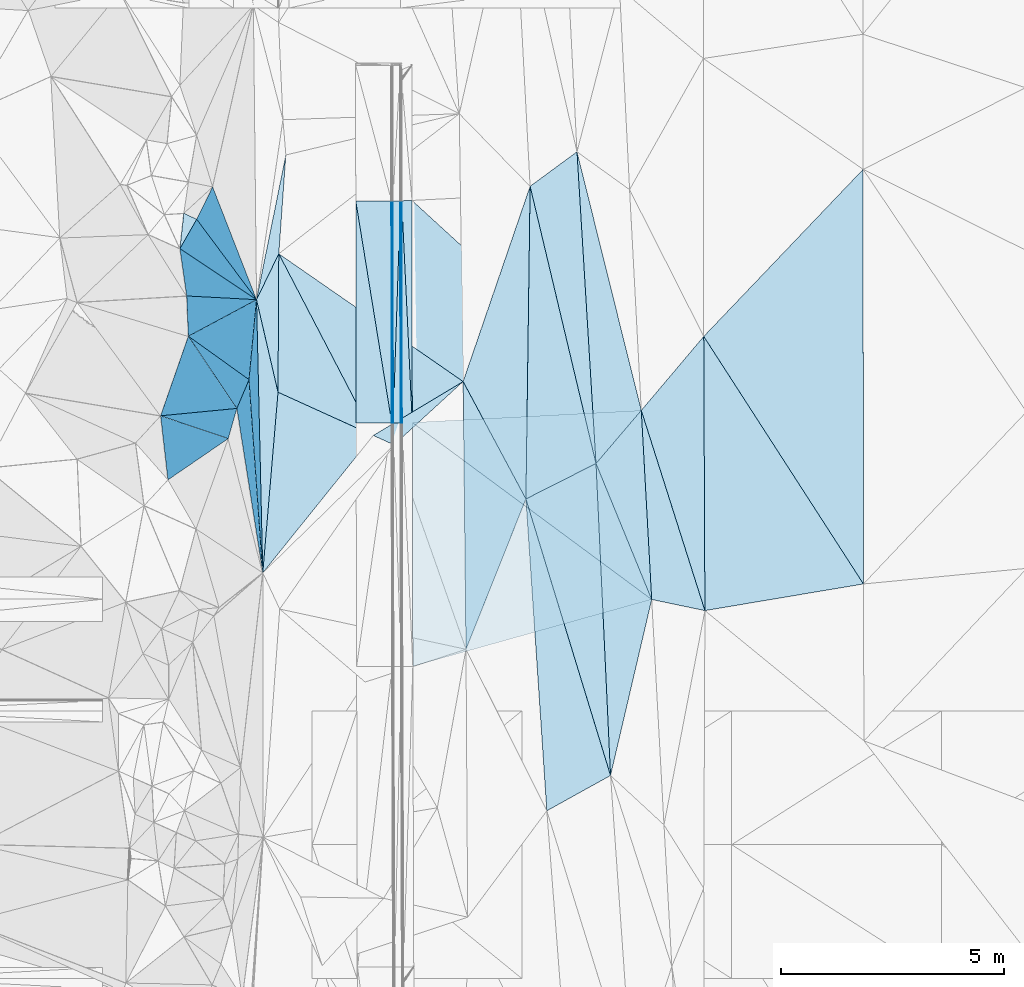
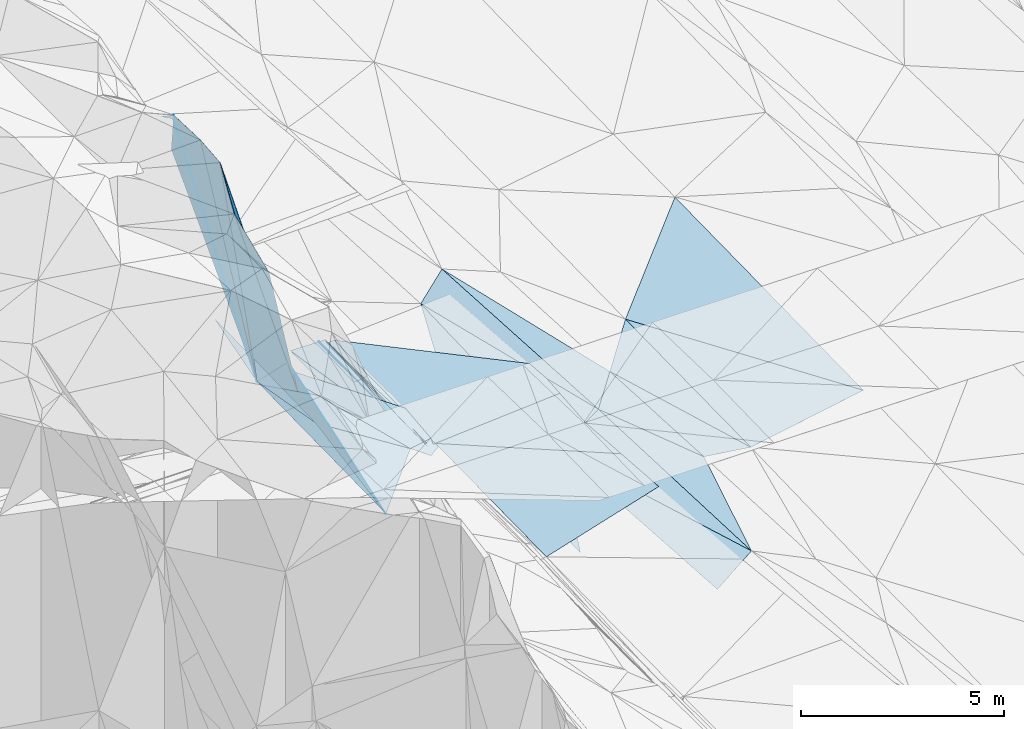
# One storey, part 82 of 275: 45 plates.
"""IFC2X3 building model written with IfcOpenShell, lengths in millimetres."""

import ifcopenshell
import ifcopenshell.guid

model = None  # the IFC model being written
_history = None  # IfcOwnerHistory: only IFC2X3 demands one
_inside = {}  # id of a spatial element -> (the spatial element, [elements in it])
_under = {}  # id of a project, library or spatial element -> (it, [spatial elements below it])
_declared = {}  # id of a project -> (the project, [libraries it declares])
_typed = {}  # id of a type object -> (the type object, [elements of that type])
_made_of = {}  # id of a material, layer set ... -> (it, [elements and type objects made of it])


def new_model(schema):
    """Start an empty IFC model of exactly this schema.

    Asked for "IFC4X3", IfcOpenShell would pick the latest addendum, in which some entities
    have other attributes; the version numbers below select the first issue.
    IFC2X3 requires an IfcOwnerHistory on every rooted entity: one is made here for all.
    """
    global model, _history
    if schema == "IFC4X3":
        model = ifcopenshell.file(schema_version=(4, 3, 0, 0))
    else:
        model = ifcopenshell.file(schema=schema)
    _inside.clear()
    _under.clear()
    _declared.clear()
    _typed.clear()
    _made_of.clear()
    _history = None
    if model.schema == "IFC2X3":
        org = make("IfcOrganization", Name="unknown")
        user = make(
            "IfcPersonAndOrganization",
            ThePerson=make("IfcPerson", FamilyName="unknown"),
            TheOrganization=org,
        )
        app = make(
            "IfcApplication",
            ApplicationDeveloper=org,
            Version="unknown",
            ApplicationFullName="unknown",
            ApplicationIdentifier="unknown",
        )
        _history = make(
            "IfcOwnerHistory",
            OwningUser=user,
            OwningApplication=app,
            ChangeAction="ADDED",
            CreationDate=0,
        )
    return model


def make(cls, **values):
    """One entity of the class cls with the attributes given. An attribute that is None is left unset."""
    return model.create_entity(
        cls, **{name: value for name, value in values.items() if value is not None}
    )


def rooted(cls, **values):
    """An entity with a GlobalId (a new one), such as an element, a storey or a relation."""
    return make(cls, GlobalId=ifcopenshell.guid.new(), OwnerHistory=_history, **values)


def si_unit(unit_type, name, prefix=None):
    """IfcSIUnit, for example si_unit("LENGTHUNIT", "METRE", prefix="MILLI")."""
    return make("IfcSIUnit", UnitType=unit_type, Prefix=prefix, Name=name)


def assignment(units):
    """IfcUnitAssignment: the units of a project."""
    return None if units is None else make("IfcUnitAssignment", Units=units)


def point(xyz):
    """IfcCartesianPoint."""
    return None if xyz is None else make("IfcCartesianPoint", Coordinates=xyz)


def direction(xyz):
    """IfcDirection."""
    return None if xyz is None else make("IfcDirection", DirectionRatios=xyz)


def frame(location, z_axis=None, x_axis=None):
    """IfcAxis2Placement3D, a coordinate frame: its origin and axes. An axis left out is left unset."""
    return make(
        "IfcAxis2Placement3D",
        Location=point(location),
        Axis=direction(z_axis),
        RefDirection=direction(x_axis),
    )


def origin_with_axes():
    """The frame at (0, 0, 0) with the z axis (0, 0, 1) and the x axis (1, 0, 0) written out."""
    return frame((0.0, 0.0, 0.0), z_axis=(0.0, 0.0, 1.0), x_axis=(1.0, 0.0, 0.0))


def place(relative_to, where):
    """IfcLocalPlacement: puts the frame where relative to a parent placement (None: the world)."""
    return make(
        "IfcLocalPlacement", PlacementRelTo=relative_to, RelativePlacement=where
    )


def context(
    kind, dimensions, precision=None, world=None, true_north=None, identifier=None
):
    """IfcGeometricRepresentationContext, for example the 3D "Model" context."""
    return make(
        "IfcGeometricRepresentationContext",
        ContextIdentifier=identifier,
        ContextType=kind,
        CoordinateSpaceDimension=dimensions,
        Precision=precision,
        WorldCoordinateSystem=world,
        TrueNorth=true_north,
    )


def subcontext(parent, identifier, kind, view, scale=None):
    """IfcGeometricRepresentationSubContext, for example "Body" below "Model"."""
    return make(
        "IfcGeometricRepresentationSubContext",
        ContextIdentifier=identifier,
        ContextType=kind,
        ParentContext=parent,
        TargetScale=scale,
        TargetView=view,
    )


def project(units=None, contexts=None):
    """IfcProject with its units and contexts."""
    return rooted(
        "IfcProject",
        Name="project",
        RepresentationContexts=contexts,
        UnitsInContext=assignment(units),
    )


def spatial(cls, under=None, at=None, **own):
    """A site, building, storey or space (cls), placed at a placement, below another one or the project."""
    s = rooted(cls, ObjectPlacement=at, **own)
    if under is not None:
        _under.setdefault(under.id(), (under, []))[1].append(s)
    return s


def polyline(points):
    """IfcPolyline through the points."""
    return make("IfcPolyline", Points=[point(p) for p in points])


def outline(outer, holes=None, kind="AREA"):
    """IfcArbitraryClosedProfileDef: a profile drawn as a closed curve; with holes, ...WithVoids."""
    if holes is None:
        return make("IfcArbitraryClosedProfileDef", ProfileType=kind, OuterCurve=outer)
    return make(
        "IfcArbitraryProfileDefWithVoids",
        ProfileType=kind,
        OuterCurve=outer,
        InnerCurves=holes,
    )


def extrude(swept, where, along, depth):
    """IfcExtrudedAreaSolid: the profile swept, set in the frame where, extruded along a direction by depth."""
    return make(
        "IfcExtrudedAreaSolid",
        SweptArea=swept,
        Position=where,
        ExtrudedDirection=direction(along),
        Depth=depth,
    )


def shape(context_of_items, identifier, shape_type, items):
    """IfcShapeRepresentation: the items that make up one representation, for example the "Body"."""
    return make(
        "IfcShapeRepresentation",
        ContextOfItems=context_of_items,
        RepresentationIdentifier=identifier,
        RepresentationType=shape_type,
        Items=items,
    )


def material(Name=None, Category=None):
    """IfcMaterial."""
    return make("IfcMaterial", Name=Name, Category=Category)


def made_of(thing, what):
    """Note that an element or type object is made of a material, layer set ...; save() writes the relation."""
    if what is not None:
        _made_of.setdefault(what.id(), (what, []))[1].append(thing)
    return thing


def type_object(cls, material=None, **own):
    """A type object (cls), such as IfcWallType, which elements share."""
    return made_of(rooted(cls, **own), material)


def element(
    cls,
    number,
    at=None,
    inside=None,
    cuts=None,
    type_object=None,
    material=None,
    context=None,
    identifier="Body",
    shape_type=None,
    held_by="IfcProductDefinitionShape",
    body=None,
    shapes=None,
    **own,
):
    """One element of the class cls, such as IfcWall. Its Tag is "e" and its number.

    at: its placement. inside: the storey or other place that contains it. cuts: it is an
    opening in that element (IfcRelVoidsElement). A single representation is given by context,
    identifier, shape_type and body (its items); several are given by shapes. held_by: the class
    of the entity that holds the representations. save() writes the other relations.
    """
    e = rooted(cls, Tag="e%d" % number, ObjectPlacement=at, **own)
    if body is not None:
        shapes = [shape(context, identifier, shape_type, body)]
    if shapes is not None:
        e.Representation = make(held_by, Representations=shapes)
    if inside is not None:
        _inside.setdefault(inside.id(), (inside, []))[1].append(e)
    if cuts is not None:
        rooted(
            "IfcRelVoidsElement", RelatingBuildingElement=cuts, RelatedOpeningElement=e
        )
    if type_object is not None:
        _typed.setdefault(type_object.id(), (type_object, []))[1].append(e)
    return made_of(e, material)


def aggregate(whole, parts):
    """IfcRelAggregates: a whole, such as a stair, and the parts it consists of."""
    return rooted("IfcRelAggregates", RelatingObject=whole, RelatedObjects=parts)


def save(model, path):
    """Write the relations noted so far, then the file.

    IfcRelAggregates (storeys below a building ...), IfcRelContainedInSpatialStructure (elements
    in a storey), IfcRelDefinesByType, IfcRelAssociatesMaterial and IfcRelDeclares: one each for
    every whole, place, type object, material and project.
    """
    for whole, parts in _under.values():
        aggregate(whole, parts)
    for where, things in _inside.values():
        rooted(
            "IfcRelContainedInSpatialStructure",
            RelatedElements=things,
            RelatingStructure=where,
        )
    for kind, things in _typed.values():
        rooted("IfcRelDefinesByType", RelatedObjects=things, RelatingType=kind)
    for what, things in _made_of.values():
        rooted("IfcRelAssociatesMaterial", RelatedObjects=things, RelatingMaterial=what)
    for by, libraries in _declared.values():
        rooted("IfcRelDeclares", RelatingContext=by, RelatedDefinitions=libraries)
    model.write(path)


model = new_model("IFC2X3")

# Units and contexts
model_context = context("Model", 3, precision=1e-05, world=origin_with_axes())
body_context = subcontext(model_context, "Body", "Model", "MODEL_VIEW")
ifc_project = project(units=[si_unit("LENGTHUNIT", "METRE", prefix="MILLI"), si_unit("AREAUNIT", "SQUARE_METRE"), si_unit("VOLUMEUNIT", "CUBIC_METRE"), si_unit("MASSUNIT", "GRAM", prefix="KILO"), si_unit("TIMEUNIT", "SECOND"), si_unit("PLANEANGLEUNIT", "RADIAN"), si_unit("SOLIDANGLEUNIT", "STERADIAN"), si_unit("THERMODYNAMICTEMPERATUREUNIT", "DEGREE_CELSIUS"), si_unit("LUMINOUSINTENSITYUNIT", "LUMEN")], contexts=[model_context])

# Site, building, storey
site_placement = place(None, origin_with_axes())
site = spatial("IfcSite", under=ifc_project, at=site_placement, CompositionType="ELEMENT")
building_placement = place(site_placement, origin_with_axes())
building = spatial("IfcBuilding", under=site, at=building_placement, Name="Undefined", CompositionType="ELEMENT")
storey_placement = place(building_placement, origin_with_axes())
storey = spatial("IfcBuildingStorey", under=building, at=storey_placement, Name="Undefined", CompositionType="ELEMENT", Elevation=0.0)

# Plates
ifc_material = material()
plate_type_1 = type_object("IfcPlateType", PredefinedType="NOTDEFINED")
plate_1_placement = place(storey_placement, frame((-89444.618863337, 64842.7358949304, 42407.5032804779), z_axis=(0.111617782636541, 0.0258237685561745, -0.993415624789976), x_axis=(-0.869160661525397, -0.48209765936178, -0.11018888916142)))
element("IfcPlate", 1, at=plate_1_placement, inside=storey, type_object=plate_type_1, material=ifc_material, Name="00", context=body_context, shape_type="SweptSolid", body=[
    extrude(outline(polyline([(0.0, 0.0), (1642.63391113281, -5.03496266901493e-09), (-1333.244140625, 6341.60546875), (0.0, 0.0)])), frame((-8.85201319254618e-08, 2.18876761149539e-07, -0.5000001331573), z_axis=(0.0, 0.0, 1.0), x_axis=(1.0, 0.0, 0.0)), (0.0, 0.0, 1.0), 1.0),
])
plate_type_2 = type_object("IfcPlateType", PredefinedType="NOTDEFINED")
plate_2_placement = place(storey_placement, frame((-94117.6604189031, 72746.729349898, 42397.8747366378), z_axis=(-0.970138594073752, 0.00347870184175946, -0.242526301505836), x_axis=(-0.00731542211713824, 0.999022621098165, 0.043592282956971)))
element("IfcPlate", 2, at=plate_2_placement, inside=storey, type_object=plate_type_2, material=ifc_material, Name="00_PR", context=body_context, shape_type="SweptSolid", body=[
    extrude(outline(polyline([(0.0, 0.0), (4977.96826171875, -7.34871719032526e-09), (4972.70556640625, 123.581230163574), (0.0, 0.0)])), frame((-8.85201319254618e-08, 2.18876761149539e-07, -0.5000001331573), z_axis=(0.0, 0.0, 1.0), x_axis=(1.0, 0.0, 0.0)), (0.0, 0.0, 1.0), 1.0),
])
plate_3_placement = place(storey_placement, frame((-94117.6604189031, 72746.729349898, 42397.8747366378), z_axis=(-0.970141199124637, 0.00347822856618674, -0.242515887494103), x_axis=(-0.242522932028191, -0.00176481198317647, 0.970144068104894)))
element("IfcPlate", 3, at=plate_3_placement, inside=storey, type_object=plate_type_2, material=ifc_material, Name="00_PR", context=body_context, shape_type="SweptSolid", body=[
    extrude(outline(polyline([(0.0, 0.0), (123.69295501709, -7.27595761418343e-11), (210.577346801758, 4973.51220703125), (0.0, 0.0)])), frame((-8.85201319254618e-08, 2.18876761149539e-07, -0.5000001331573), z_axis=(0.0, 0.0, 1.0), x_axis=(1.0, 0.0, 0.0)), (0.0, 0.0, 1.0), 1.0),
])
plate_type_3 = type_object("IfcPlateType", PredefinedType="NOTDEFINED")
plate_4_placement = place(storey_placement, frame((-94317.1841480322, 72746.228678352, 42517.4961943579), z_axis=(-0.0200252966545819, 0.0194701752981887, -0.999609873784645), x_axis=(-0.999798643815819, -0.00167813309841074, 0.0199963920083956)))
element("IfcPlate", 4, at=plate_4_placement, inside=storey, type_object=plate_type_3, material=ifc_material, Name="00_PR", context=body_context, shape_type="SweptSolid", body=[
    extrude(outline(polyline([(0.0, 0.0), (30.0054130554199, -7.27595761418343e-11), (30.0149536132813, 4974.4365234375), (0.0, 0.0)])), frame((-8.85201319254618e-08, 2.18876761149539e-07, -0.5000001331573), z_axis=(0.0, 0.0, 1.0), x_axis=(1.0, 0.0, 0.0)), (0.0, 0.0, 1.0), 1.0),
])
plate_5_placement = place(storey_placement, frame((-94353.6008469605, 77719.6646390638, 42615.0971946187), z_axis=(-0.020009290866159, 0.0194702016103161, -0.999610193789703), x_axis=(0.999799667779248, 0.000886280119676432, -0.0199959699953689)))
element("IfcPlate", 5, at=plate_5_placement, inside=storey, type_object=plate_type_3, material=ifc_material, Name="00_PR", context=body_context, shape_type="SweptSolid", body=[
    extrude(outline(polyline([(0.0, 0.0), (30.006046295166, -5.82076609134674e-11), (33.9531784057617, 4974.4111328125), (0.0, 0.0)])), frame((-8.85201319254618e-08, 2.18876761149539e-07, -0.5000001331573), z_axis=(0.0, 0.0, 1.0), x_axis=(1.0, 0.0, 0.0)), (0.0, 0.0, 1.0), 1.0),
])
plate_type_4 = type_object("IfcPlateType", PredefinedType="NOTDEFINED")
plate_6_placement = place(storey_placement, frame((-95153.6003904892, 77718.9630360176, 42631.0971939899), z_axis=(-0.020009290866159, 0.0194702016103161, -0.999610193789703), x_axis=(0.999799675411591, 0.000876829116764039, -0.0199960050404666)))
element("IfcPlate", 6, at=plate_6_placement, inside=storey, type_object=plate_type_4, material=ifc_material, Name="00_PR", context=body_context, shape_type="SweptSolid", body=[
    extrude(outline(polyline([(0.0, 0.0), (800.159851074219, -2.4156179279089e-09), (804.154602050781, 4974.4345703125), (0.0, 0.0)])), frame((-8.85201319254618e-08, 2.18876761149539e-07, -0.5000001331573), z_axis=(0.0, 0.0, 1.0), x_axis=(1.0, 0.0, 0.0)), (0.0, 0.0, 1.0), 1.0),
])
plate_7_placement = place(storey_placement, frame((-94347.1835203325, 72746.1783233951, 42518.0961940679), z_axis=(-0.0200253858209845, 0.0194675856213308, -0.999609922436146), x_axis=(-0.999798609242098, -0.00170328511816342, 0.0199959940331207)))
element("IfcPlate", 7, at=plate_7_placement, inside=storey, type_object=plate_type_4, material=ifc_material, Name="00_PR", context=body_context, shape_type="SweptSolid", body=[
    extrude(outline(polyline([(0.0, 0.0), (800.160278320313, 5.5297277867794e-09), (800.0439453125, 4975.09765625), (0.0, 0.0)])), frame((-8.85201319254618e-08, 2.18876761149539e-07, -0.5000001331573), z_axis=(0.0, 0.0, 1.0), x_axis=(1.0, 0.0, 0.0)), (0.0, 0.0, 1.0), 1.0),
])
plate_type_5 = type_object("IfcPlateType", PredefinedType="NOTDEFINED")
plate_8_placement = place(storey_placement, frame((-94123.5755587747, 77720.0284364157, 42494.4973540296), z_axis=(0.0321667670477351, 0.01953207219902, -0.999291647745196), x_axis=(0.0475300560924656, -0.998707779540465, -0.0179906879579957)))
element("IfcPlate", 8, at=plate_8_placement, inside=storey, type_object=plate_type_5, material=ifc_material, Name="00_PR", context=body_context, shape_type="SweptSolid", body=[
    extrude(outline(polyline([(0.0, 0.0), (4973.85107421875, 3.33529897034168e-08), (4968.91455078125, 230.135818481445), (0.0, 0.0)])), frame((-8.85201319254618e-08, 2.18876761149539e-07, -0.5000001331573), z_axis=(0.0, 0.0, 1.0), x_axis=(1.0, 0.0, 0.0)), (0.0, 0.0, 1.0), 1.0),
])
plate_9_placement = place(storey_placement, frame((-93893.5824311411, 77728.6313530642, 42502.0183500543), z_axis=(0.0319478192432614, 0.0195217824957028, -0.999298872637106), x_axis=(0.00128876911653835, -0.999809210568277, -0.0194905499410143)))
element("IfcPlate", 9, at=plate_9_placement, inside=storey, type_object=plate_type_5, material=ifc_material, Name="00_PR", context=body_context, shape_type="SweptSolid", body=[
    extrude(outline(polyline([(0.0, 0.0), (4976.97607421875, 3.05008143186569e-08), (8.45146083831787, 230.121795654297), (0.0, 0.0)])), frame((-8.85201319254618e-08, 2.18876761149539e-07, -0.5000001331573), z_axis=(0.0, 0.0, 1.0), x_axis=(1.0, 0.0, 0.0)), (0.0, 0.0, 1.0), 1.0),
])
plate_type_6 = type_object("IfcPlateType", PredefinedType="NOTDEFINED")
plate_10_placement = place(storey_placement, frame((-94317.1741466871, 72746.2286934931, 42517.4960946812), z_axis=(-1.70839782126875e-05, 0.0194999851390157, -0.99980985706669), x_axis=(-0.00128993512309353, 0.999809024974403, 0.0194999909515573)))
element("IfcPlate", 10, at=plate_10_placement, inside=storey, type_object=plate_type_6, material=ifc_material, Name="00_PR", context=body_context, shape_type="SweptSolid", body=[
    extrude(outline(polyline([(0.0, 0.0), (4974.41259765625, -2.84344423562288e-08), (4974.34228515625, 169.999572753906), (0.0, 0.0)])), frame((-8.85201319254618e-08, 2.18876761149539e-07, -0.5000001331573), z_axis=(0.0, 0.0, 1.0), x_axis=(1.0, 0.0, 0.0)), (0.0, 0.0, 1.0), 1.0),
])
plate_11_placement = place(storey_placement, frame((-94153.591302071, 77719.8401820508, 42614.4970950768), z_axis=(-3.33079408345215e-05, 0.0195005182108535, -0.999809846260822), x_axis=(0.00129015010064996, -0.999809013891711, -0.0195005449565535)))
element("IfcPlate", 11, at=plate_11_placement, inside=storey, type_object=plate_type_6, material=ifc_material, Name="00_PR", context=body_context, shape_type="SweptSolid", body=[
    extrude(outline(polyline([(0.0, 0.0), (4974.27099609375, -3.19123500958085e-08), (4974.34228515625, 170.000640869141), (0.0, 0.0)])), frame((-8.85201319254618e-08, 2.18876761149539e-07, -0.5000001331573), z_axis=(0.0, 0.0, 1.0), x_axis=(1.0, 0.0, 0.0)), (0.0, 0.0, 1.0), 1.0),
])
plate_type_7 = type_object("IfcPlateType", PredefinedType="NOTDEFINED")
plate_12_placement = place(storey_placement, frame((-88755.828340706, 73023.8678780256, 42559.3353079388), z_axis=(0.029013693312706, 0.019711028854778, -0.999384651143814), x_axis=(0.0549715490951405, -0.998323959821758, -0.0180941989567237)))
element("IfcPlate", 12, at=plate_12_placement, inside=storey, type_object=plate_type_7, material=ifc_material, Name="00_PR", context=body_context, shape_type="SweptSolid", body=[
    extrude(outline(polyline([(0.0, 0.0), (4244.6201171875, 2.48837750405073e-09), (-8.47717952728271, 5140.81640625), (0.0, 0.0)])), frame((-8.85201319254618e-08, 2.18876761149539e-07, -0.5000001331573), z_axis=(0.0, 0.0, 1.0), x_axis=(1.0, 0.0, 0.0)), (0.0, 0.0, 1.0), 1.0),
])
plate_type_8 = type_object("IfcPlateType", PredefinedType="NOTDEFINED")
plate_13_placement = place(storey_placement, frame((-93887.169717697, 72752.6048438911, 42405.0143065105), z_axis=(0.0290239089952379, 0.0195197531379186, -0.999388108766595), x_axis=(-0.00128876910606511, 0.999809210568024, 0.0194905499547063)))
element("IfcPlate", 13, at=plate_13_placement, inside=storey, type_object=plate_type_8, material=ifc_material, Name="00_PR", context=body_context, shape_type="SweptSolid", body=[
    extrude(outline(polyline([(0.0, 0.0), (4976.97607421875, 3.05008143186569e-08), (267.605865478516, 5133.853515625), (0.0, 0.0)])), frame((-8.85201319254618e-08, 2.18876761149539e-07, -0.5000001331573), z_axis=(0.0, 0.0, 1.0), x_axis=(1.0, 0.0, 0.0)), (0.0, 0.0, 1.0), 1.0),
])
plate_type_9 = type_object("IfcPlateType", PredefinedType="NOTDEFINED")
plate_14_placement = place(storey_placement, frame((-93875.3877965251, 67289.1652421238, 42297.782307639), z_axis=(0.0289890427295221, 0.0196776603535674, -0.99938602405909), x_axis=(-0.00215608511128748, 0.999805118314905, 0.0196233709721959)))
element("IfcPlate", 14, at=plate_14_placement, inside=storey, type_object=plate_type_9, material=ifc_material, Name="00_PR", context=body_context, shape_type="SweptSolid", body=[
    extrude(outline(polyline([(0.0, 0.0), (5464.50439453125, 1.28202373161912e-08), (1488.98913574219, 5358.36767578125), (0.0, 0.0)])), frame((-8.85201319254618e-08, 2.18876761149539e-07, -0.5000001331573), z_axis=(0.0, 0.0, 1.0), x_axis=(1.0, 0.0, 0.0)), (0.0, 0.0, 1.0), 1.0),
])
plate_type_10 = type_object("IfcPlateType", PredefinedType="NOTDEFINED")
plate_15_placement = place(storey_placement, frame((-99526.9349128616, 72902.6245616917, 51199.8605269256), z_axis=(-0.893965103901235, 0.350744833349942, -0.278934499273888), x_axis=(0.326341170728292, 0.936102852952924, 0.131197900063545)))
element("IfcPlate", 15, at=plate_15_placement, inside=storey, type_object=plate_type_10, material=ifc_material, Name="00", context=body_context, shape_type="SweptSolid", body=[
    extrude(outline(polyline([(0.0, 0.0), (1905.51831054688, 6.57746568322182e-09), (20.9916648864746, 5542.64892578125), (0.0, 0.0)])), frame((-8.85201319254618e-08, 2.18876761149539e-07, -0.5000001331573), z_axis=(0.0, 0.0, 1.0), x_axis=(1.0, 0.0, 0.0)), (0.0, 0.0, 1.0), 1.0),
])
plate_type_11 = type_object("IfcPlateType", PredefinedType="NOTDEFINED")
plate_16_placement = place(storey_placement, frame((-88522.4927132035, 68786.362588593, 42529.5003792916), z_axis=(0.0338025597203587, 0.0207254823291996, -0.999213611465824), x_axis=(-0.378908875488096, 0.925412018442613, 0.00637653497719486)))
element("IfcPlate", 16, at=plate_16_placement, inside=storey, type_object=plate_type_11, material=ifc_material, Name="00", context=body_context, shape_type="SweptSolid", body=[
    extrude(outline(polyline([(0.0, 0.0), (3293.32446289063, 7.50151230022311e-09), (4010.36108398438, 1390.79284667969), (0.0, 0.0)])), frame((-8.85201319254618e-08, 2.18876761149539e-07, -0.5000001331573), z_axis=(0.0, 0.0, 1.0), x_axis=(1.0, 0.0, 0.0)), (0.0, 0.0, 1.0), 1.0),
])
plate_type_12 = type_object("IfcPlateType", PredefinedType="NOTDEFINED")
plate_17_placement = place(storey_placement, frame((-91246.9022901931, 78045.3959095917, 42477.5079083627), z_axis=(0.174731865229497, 0.0299721132208858, -0.984159767366303), x_axis=(0.795259158073839, 0.585045632730831, 0.159010940259691)))
element("IfcPlate", 17, at=plate_17_placement, inside=storey, type_object=plate_type_12, material=ifc_material, Name="00", context=body_context, shape_type="SweptSolid", body=[
    extrude(outline(polyline([(0.0, 0.0), (1320.66381835938, 1.06228981167078e-09), (-2448.02563476563, 5896.92333984375), (0.0, 0.0)])), frame((-8.85201319254618e-08, 2.18876761149539e-07, -0.5000001331573), z_axis=(0.0, 0.0, 1.0), x_axis=(1.0, 0.0, 0.0)), (0.0, 0.0, 1.0), 1.0),
])
plate_type_13 = type_object("IfcPlateType", PredefinedType="NOTDEFINED")
plate_18_placement = place(storey_placement, frame((-97545.4361877179, 73712.9885815757, 45539.8724302355), z_axis=(-0.936376961903715, 0.241057644960747, -0.255126237423647), x_axis=(-0.339766455862014, -0.804900041873057, 0.486512772765234)))
element("IfcPlate", 18, at=plate_18_placement, inside=storey, type_object=plate_type_13, material=ifc_material, Name="00", context=body_context, shape_type="SweptSolid", body=[
    extrude(outline(polyline([(0.0, 0.0), (801.623352050781, 5.23868948221207e-10), (2553.81787109375, 5585.89404296875), (0.0, 0.0)])), frame((-8.85201319254618e-08, 2.18876761149539e-07, -0.5000001331573), z_axis=(0.0, 0.0, 1.0), x_axis=(1.0, 0.0, 0.0)), (0.0, 0.0, 1.0), 1.0),
])
plate_type_14 = type_object("IfcPlateType", PredefinedType="NOTDEFINED")
plate_19_placement = place(storey_placement, frame((-97237.6372222059, 69383.6968796635, 43503.7932261013), z_axis=(-0.901099746077251, 0.130418655315721, -0.413533822032919), x_axis=(-0.130397977254679, 0.828045649039805, 0.545285953087127)))
element("IfcPlate", 19, at=plate_19_placement, inside=storey, type_object=plate_type_14, material=ifc_material, Name="00", context=body_context, shape_type="SweptSolid", body=[
    extrude(outline(polyline([(0.0, 0.0), (4449.0419921875, -8.53469828143716e-09), (4735.1416015625, 748.830383300781), (0.0, 0.0)])), frame((-8.85201319254618e-08, 2.18876761149539e-07, -0.5000001331573), z_axis=(0.0, 0.0, 1.0), x_axis=(1.0, 0.0, 0.0)), (0.0, 0.0, 1.0), 1.0),
])
plate_type_15 = type_object("IfcPlateType", PredefinedType="NOTDEFINED")
plate_20_placement = place(storey_placement, frame((-97817.7752682129, 73067.8290097536, 45929.8623472046), z_axis=(-0.885098503409818, 0.375254186611925, -0.275290636767623), x_axis=(-0.252828330677899, -0.884304602678622, -0.392534335935127)))
element("IfcPlate", 20, at=plate_20_placement, inside=storey, type_object=plate_type_15, material=ifc_material, Name="00", context=body_context, shape_type="SweptSolid", body=[
    extrude(outline(polyline([(0.0, 0.0), (764.264343261719, 2.09547579288483e-09), (-1490.45288085938, 5338.53466796875), (0.0, 0.0)])), frame((-8.85201319254618e-08, 2.18876761149539e-07, -0.5000001331573), z_axis=(0.0, 0.0, 1.0), x_axis=(1.0, 0.0, 0.0)), (0.0, 0.0, 1.0), 1.0),
])
plate_type_16 = type_object("IfcPlateType", PredefinedType="NOTDEFINED")
plate_21_placement = place(storey_placement, frame((-98011.0408968191, 72391.8333191524, 45629.8660662042), z_axis=(-0.960996882613753, 0.068837372997665, -0.267855199100985), x_axis=(-0.27619437110143, -0.18915092210665, 0.942304938986361)))
element("IfcPlate", 21, at=plate_21_placement, inside=storey, type_object=plate_type_16, material=ifc_material, Name="00", context=body_context, shape_type="SweptSolid", body=[
    extrude(outline(polyline([(0.0, 0.0), (4892.25927734375, -1.82189978659153e-08), (5570.7392578125, 1597.048828125), (0.0, 0.0)])), frame((-8.85201319254618e-08, 2.18876761149539e-07, -0.5000001331573), z_axis=(0.0, 0.0, 1.0), x_axis=(1.0, 0.0, 0.0)), (0.0, 0.0, 1.0), 1.0),
])
plate_type_17 = type_object("IfcPlateType", PredefinedType="NOTDEFINED")
plate_22_placement = place(storey_placement, frame((-96895.8161003144, 73431.36735261, 43659.5142441809), z_axis=(-0.236255539126644, 0.0201061786781543, -0.971482918949654), x_axis=(-0.225560327579383, 0.971341302561202, 0.0749574049776886)))
element("IfcPlate", 22, at=plate_22_placement, inside=storey, type_object=plate_type_17, material=ifc_material, Name="00", context=body_context, shape_type="SweptSolid", body=[
    extrude(outline(polyline([(0.0, 0.0), (2134.54565429688, -1.22672645375133e-08), (3013.56396484375, 737.449340820313), (0.0, 0.0)])), frame((-8.85201319254618e-08, 2.18876761149539e-07, -0.5000001331573), z_axis=(0.0, 0.0, 1.0), x_axis=(1.0, 0.0, 0.0)), (0.0, 0.0, 1.0), 1.0),
])
plate_type_18 = type_object("IfcPlateType", PredefinedType="NOTDEFINED")
plate_23_placement = place(storey_placement, frame((-98905.1252013776, 74686.1569161123, 51449.8968953098), z_axis=(-0.972665374619554, -0.106825266438722, -0.206180579751098), x_axis=(0.195220977160067, 0.104612139896346, -0.97516412478258)))
element("IfcPlate", 23, at=plate_23_placement, inside=storey, type_object=plate_type_18, material=ifc_material, Name="00", context=body_context, shape_type="SweptSolid", body=[
    extrude(outline(polyline([(0.0, 0.0), (7824.32373046875, 1.78260961547494e-08), (5926.8330078125, 1611.47521972656), (0.0, 0.0)])), frame((-8.85201319254618e-08, 2.18876761149539e-07, -0.5000001331573), z_axis=(0.0, 0.0, 1.0), x_axis=(1.0, 0.0, 0.0)), (0.0, 0.0, 1.0), 1.0),
])
plate_type_19 = type_object("IfcPlateType", PredefinedType="NOTDEFINED")
plate_24_placement = place(storey_placement, frame((-97237.2472762929, 69383.6559207232, 43503.5042452178), z_axis=(-0.120978364273596, 0.0484179656022729, -0.991473618400723), x_axis=(-0.0228320855741197, 0.998409762151338, 0.0515426300186985)))
element("IfcPlate", 24, at=plate_24_placement, inside=storey, type_object=plate_type_19, material=ifc_material, Name="00", context=body_context, shape_type="SweptSolid", body=[
    extrude(outline(polyline([(0.0, 0.0), (6130.84765625, -2.41125235334039e-08), (4041.53247070313, 437.090545654297), (0.0, 0.0)])), frame((-8.85201319254618e-08, 2.18876761149539e-07, -0.5000001331573), z_axis=(0.0, 0.0, 1.0), x_axis=(1.0, 0.0, 0.0)), (0.0, 0.0, 1.0), 1.0),
])
plate_type_20 = type_object("IfcPlateType", PredefinedType="NOTDEFINED")
plate_25_placement = place(storey_placement, frame((-92683.5117807389, 67670.551737333, 41770.5253671448), z_axis=(0.311928555269229, 0.0405245911667071, -0.949240925117761), x_axis=(-0.0107042575474713, 0.999176443251114, 0.0391389080380563)))
element("IfcPlate", 25, at=plate_25_placement, inside=storey, type_object=plate_type_20, material=ifc_material, Name="00", context=body_context, shape_type="SweptSolid", body=[
    extrude(outline(polyline([(0.0, 0.0), (6004.25537109375, 5.23868948221207e-09), (3374.2734375, 1451.22302246094), (0.0, 0.0)])), frame((-8.85201319254618e-08, 2.18876761149539e-07, -0.5000001331573), z_axis=(0.0, 0.0, 1.0), x_axis=(1.0, 0.0, 0.0)), (0.0, 0.0, 1.0), 1.0),
])
plate_type_21 = type_object("IfcPlateType", PredefinedType="NOTDEFINED")
plate_26_placement = place(storey_placement, frame((-96719.7695113017, 78746.3148947997, 43519.5020192317), z_axis=(-0.0165373947187794, -0.0888138181243595, -0.995910949978003), x_axis=(-0.0712255523608248, -0.993412101902716, 0.0897736959477695)))
element("IfcPlate", 26, at=plate_26_placement, inside=storey, type_object=plate_type_21, material=ifc_material, Name="00", context=body_context, shape_type="SweptSolid", body=[
    extrude(outline(polyline([(0.0, 0.0), (2227.82397460938, 1.12049747258425e-09), (3294.0302734375, 423.921173095703), (0.0, 0.0)])), frame((-8.85201319254618e-08, 2.18876761149539e-07, -0.5000001331573), z_axis=(0.0, 0.0, 1.0), x_axis=(1.0, 0.0, 0.0)), (0.0, 0.0, 1.0), 1.0),
])
plate_type_22 = type_object("IfcPlateType", PredefinedType="NOTDEFINED")
plate_27_placement = place(storey_placement, frame((-99007.0875013528, 77439.7954360325, 51199.6252177601), z_axis=(-0.456508555733989, -0.479406470526146, -0.74951275810311), x_axis=(0.872492883644568, -0.406184288577308, -0.271607237942091)))
element("IfcPlate", 27, at=plate_27_placement, inside=storey, type_object=plate_type_22, material=ifc_material, Name="00", context=body_context, shape_type="SweptSolid", body=[
    extrude(outline(polyline([(0.0, 0.0), (331.36083984375, -1.82262738235295e-09), (94.1571731567383, 969.966186523438), (0.0, 0.0)])), frame((-8.85201319254618e-08, 2.18876761149539e-07, -0.5000001331573), z_axis=(0.0, 0.0, 1.0), x_axis=(1.0, 0.0, 0.0)), (0.0, 0.0, 1.0), 1.0),
])
plate_type_23 = type_object("IfcPlateType", PredefinedType="NOTDEFINED")
plate_28_placement = place(storey_placement, frame((-98718.2122566056, 77305.5865701523, 51109.8790209249), z_axis=(-0.925952106124408, 0.289989132058421, -0.241907007859999), x_axis=(0.175748817291903, -0.236071258755388, -0.955710580672906)))
element("IfcPlate", 28, at=plate_28_placement, inside=storey, type_object=plate_type_23, material=ifc_material, Name="00", context=body_context, shape_type="SweptSolid", body=[
    extrude(outline(polyline([(0.0, 0.0), (7627.83203125, 2.07292032428086e-08), (-531.898193359375, 845.094299316406), (0.0, 0.0)])), frame((-8.85201319254618e-08, 2.18876761149539e-07, -0.5000001331573), z_axis=(0.0, 0.0, 1.0), x_axis=(1.0, 0.0, 0.0)), (0.0, 0.0, 1.0), 1.0),
])
plate_type_24 = type_object("IfcPlateType", PredefinedType="NOTDEFINED")
plate_29_placement = place(storey_placement, frame((-97377.6634238785, 75504.7212151671, 43819.9427660834), z_axis=(-0.993290837836147, -0.0168083813639197, -0.114414989344445), x_axis=(0.0228320856720504, -0.998409762147871, -0.0515426300424877)))
element("IfcPlate", 29, at=plate_29_placement, inside=storey, type_object=plate_type_24, material=ifc_material, Name="00", context=body_context, shape_type="SweptSolid", body=[
    extrude(outline(polyline([(0.0, 0.0), (6130.84765625, -2.41125235334039e-08), (1696.52746582031, 1821.84509277344), (0.0, 0.0)])), frame((-8.85201319254618e-08, 2.18876761149539e-07, -0.5000001331573), z_axis=(0.0, 0.0, 1.0), x_axis=(1.0, 0.0, 0.0)), (0.0, 0.0, 1.0), 1.0),
])
plate_type_25 = type_object("IfcPlateType", PredefinedType="NOTDEFINED")
plate_30_placement = place(storey_placement, frame((-89444.6560042261, 64842.7340774435, 42407.5004557413), z_axis=(0.0373439168340728, 0.022174403682829, -0.999056418675543), x_axis=(-0.0465268995538914, 0.998708147253829, 0.0204275359925161)))
element("IfcPlate", 30, at=plate_30_placement, inside=storey, type_object=plate_type_25, material=ifc_material, Name="00", context=body_context, shape_type="SweptSolid", body=[
    extrude(outline(polyline([(0.0, 0.0), (7000.3544921875, -2.15222826227546e-08), (3898.12133789063, 1105.50170898438), (0.0, 0.0)])), frame((-8.85201319254618e-08, 2.18876761149539e-07, -0.5000001331573), z_axis=(0.0, 0.0, 1.0), x_axis=(1.0, 0.0, 0.0)), (0.0, 0.0, 1.0), 1.0),
])
plate_type_26 = type_object("IfcPlateType", PredefinedType="NOTDEFINED")
plate_31_placement = place(storey_placement, frame((-88755.8265651422, 73023.8688442054, 42609.5003715389), z_axis=(0.0327755641257359, 0.0216019544793076, -0.999229261960894), x_axis=(-0.648369271380963, -0.760391721310291, -0.0377056771811845)))
element("IfcPlate", 31, at=plate_31_placement, inside=storey, type_object=plate_type_26, material=ifc_material, Name="00", context=body_context, shape_type="SweptSolid", body=[
    extrude(outline(polyline([(0.0, 0.0), (1564.75109863281, 1.57160684466362e-09), (-3474.56079101563, 4856.13623046875), (0.0, 0.0)])), frame((-8.85201319254618e-08, 2.18876761149539e-07, -0.5000001331573), z_axis=(0.0, 0.0, 1.0), x_axis=(1.0, 0.0, 0.0)), (0.0, 0.0, 1.0), 1.0),
])
plate_type_27 = type_object("IfcPlateType", PredefinedType="NOTDEFINED")
plate_32_placement = place(storey_placement, frame((-87356.4704042934, 74681.2163072877, 42689.5003430475), z_axis=(0.0300064121012802, 0.0229000282768895, -0.999287348032449), x_axis=(0.00431543567324925, -0.999731174139613, -0.022780616066739)))
element("IfcPlate", 32, at=plate_32_placement, inside=storey, type_object=plate_type_27, material=ifc_material, Name="00", context=body_context, shape_type="SweptSolid", body=[
    extrude(outline(polyline([(0.0, 0.0), (6145.57568359375, -3.14903445541859e-08), (1652.68493652344, 1407.13635253906), (0.0, 0.0)])), frame((-8.85201319254618e-08, 2.18876761149539e-07, -0.5000001331573), z_axis=(0.0, 0.0, 1.0), x_axis=(1.0, 0.0, 0.0)), (0.0, 0.0, 1.0), 1.0),
])
plate_type_28 = type_object("IfcPlateType", PredefinedType="NOTDEFINED")
plate_33_placement = place(storey_placement, frame((-97377.6553751076, 75504.7674886127, 43819.9007703412), z_axis=(-0.977188059161115, 0.0757464372652622, -0.198408604335982), x_axis=(-0.175748817291369, 0.236071258756997, 0.955710580672607)))
element("IfcPlate", 33, at=plate_33_placement, inside=storey, type_object=plate_type_28, material=ifc_material, Name="00", context=body_context, shape_type="SweptSolid", body=[
    extrude(outline(polyline([(0.0, 0.0), (7627.83203125, 2.07292032428086e-08), (6322.1298828125, 1067.86743164063), (0.0, 0.0)])), frame((-8.85201319254618e-08, 2.18876761149539e-07, -0.5000001331573), z_axis=(0.0, 0.0, 1.0), x_axis=(1.0, 0.0, 0.0)), (0.0, 0.0, 1.0), 1.0),
])
plate_type_29 = type_object("IfcPlateType", PredefinedType="NOTDEFINED")
plate_34_placement = place(storey_placement, frame((-98905.1291089042, 74686.2061815061, 51449.9013982044), z_axis=(-0.980337854937862, -0.00833079942972603, -0.19715041962089), x_axis=(-0.0413479146789134, 0.985600644019004, 0.163956459040291)))
element("IfcPlate", 34, at=plate_34_placement, inside=storey, type_object=plate_type_29, material=ifc_material, Name="00", context=body_context, shape_type="SweptSolid", body=[
    extrude(outline(polyline([(0.0, 0.0), (914.877014160156, 4.29281499236822e-10), (-507.412445068359, 7807.853515625), (0.0, 0.0)])), frame((-8.85201319254618e-08, 2.18876761149539e-07, -0.5000001331573), z_axis=(0.0, 0.0, 1.0), x_axis=(1.0, 0.0, 0.0)), (0.0, 0.0, 1.0), 1.0),
])
plate_type_30 = type_object("IfcPlateType", PredefinedType="NOTDEFINED")
plate_35_placement = place(storey_placement, frame((-91341.0040226148, 71039.0671002383, 42355.503206343), z_axis=(0.110459467717157, 0.0254681032188268, -0.993554267118851), x_axis=(0.886802122049896, 0.448843789634447, 0.110096543244508)))
element("IfcPlate", 35, at=plate_35_placement, inside=storey, type_object=plate_type_30, material=ifc_material, Name="00", context=body_context, shape_type="SweptSolid", body=[
    extrude(outline(polyline([(0.0, 0.0), (1771.17272949219, 3.44880390912294e-09), (-1093.74194335938, 6387.27099609375), (0.0, 0.0)])), frame((-8.85201319254618e-08, 2.18876761149539e-07, -0.5000001331573), z_axis=(0.0, 0.0, 1.0), x_axis=(1.0, 0.0, 0.0)), (0.0, 0.0, 1.0), 1.0),
])
plate_type_31 = type_object("IfcPlateType", PredefinedType="NOTDEFINED")
plate_36_placement = place(storey_placement, frame((-92748.1458468047, 73669.9181523237, 42005.5512710232), z_axis=(-0.41406249048068, 0.152218729932709, -0.897430616947411), x_axis=(-0.719377233946963, -0.658804057792502, 0.220167228975954)))
element("IfcPlate", 36, at=plate_36_placement, inside=storey, type_object=plate_type_31, material=ifc_material, Name="00", context=body_context, shape_type="SweptSolid", body=[
    extrude(outline(polyline([(0.0, 0.0), (2152.90893554688, 6.44649844616652e-09), (2403.7880859375, 509.469970703125), (0.0, 0.0)])), frame((-8.85201319254618e-08, 2.18876761149539e-07, -0.5000001331573), z_axis=(0.0, 0.0, 1.0), x_axis=(1.0, 0.0, 0.0)), (0.0, 0.0, 1.0), 1.0),
])
plate_type_32 = type_object("IfcPlateType", PredefinedType="NOTDEFINED")
plate_37_placement = place(storey_placement, frame((-89770.3218036156, 71834.0421332472, 42550.5033875232), z_axis=(0.115336462328665, 0.0157459048038482, -0.993201674857336), x_axis=(-0.886802122055234, -0.448843789628777, -0.110096543224621)))
element("IfcPlate", 37, at=plate_37_placement, inside=storey, type_object=plate_type_32, material=ifc_material, Name="00", context=body_context, shape_type="SweptSolid", body=[
    extrude(outline(polyline([(0.0, 0.0), (1771.17272949219, 3.44880390912294e-09), (-1470.42626953125, 6213.2421875), (0.0, 0.0)])), frame((-8.85201319254618e-08, 2.18876761149539e-07, -0.5000001331573), z_axis=(0.0, 0.0, 1.0), x_axis=(1.0, 0.0, 0.0)), (0.0, 0.0, 1.0), 1.0),
])
plate_type_33 = type_object("IfcPlateType", PredefinedType="NOTDEFINED")
plate_38_placement = place(storey_placement, frame((-94761.4958915184, 72461.6043378285, 42729.5372379804), z_axis=(-0.372763398567803, 0.0671171697468592, -0.925495939598523), x_axis=(-0.615084384876742, -0.764655139847783, 0.19228550799571)))
element("IfcPlate", 38, at=plate_38_placement, inside=storey, type_object=plate_type_33, material=ifc_material, Name="00", context=body_context, shape_type="SweptSolid", body=[
    extrude(outline(polyline([(0.0, 0.0), (4025.26440429688, -2.58878571912646e-08), (750.102294921875, 2407.9755859375), (0.0, 0.0)])), frame((-8.85201319254618e-08, 2.18876761149539e-07, -0.5000001331573), z_axis=(0.0, 0.0, 1.0), x_axis=(1.0, 0.0, 0.0)), (0.0, 0.0, 1.0), 1.0),
])
plate_type_34 = type_object("IfcPlateType", PredefinedType="NOTDEFINED")
plate_39_placement = place(storey_placement, frame((-94761.5053756773, 72461.5807669202, 42729.540054182), z_axis=(-0.391729872908511, 0.0199727490712599, -0.919863465936994), x_axis=(-0.846273548883795, 0.384515140242335, 0.368739999707171)))
element("IfcPlate", 39, at=plate_39_placement, inside=storey, type_object=plate_type_34, material=ifc_material, Name="00", context=body_context, shape_type="SweptSolid", body=[
    extrude(outline(polyline([(0.0, 0.0), (2522.10229492188, 1.39407347887754e-08), (3722.3310546875, 2860.91772460938), (0.0, 0.0)])), frame((-8.85201319254618e-08, 2.18876761149539e-07, -0.5000001331573), z_axis=(0.0, 0.0, 1.0), x_axis=(1.0, 0.0, 0.0)), (0.0, 0.0, 1.0), 1.0),
])
plate_type_35 = type_object("IfcPlateType", PredefinedType="NOTDEFINED")
plate_40_placement = place(storey_placement, frame((-96878.618903961, 76533.231882794, 43719.5337862121), z_axis=(-0.359237763047169, 0.0399139464542443, -0.932392142008561), x_axis=(0.777849719088121, -0.539225571357298, -0.322777938696138)))
element("IfcPlate", 40, at=plate_40_placement, inside=storey, type_object=plate_type_35, material=ifc_material, Name="00", context=body_context, shape_type="SweptSolid", body=[
    extrude(outline(polyline([(0.0, 0.0), (5310.15234375, 1.68729457072914e-08), (4161.89208984375, 2172.384765625), (0.0, 0.0)])), frame((-8.85201319254618e-08, 2.18876761149539e-07, -0.5000001331573), z_axis=(0.0, 0.0, 1.0), x_axis=(1.0, 0.0, 0.0)), (0.0, 0.0, 1.0), 1.0),
])
plate_type_36 = type_object("IfcPlateType", PredefinedType="NOTDEFINED")
plate_41_placement = place(storey_placement, frame((-87356.4737378508, 74681.215093522, 42689.5002264838), z_axis=(0.0233337894185793, 0.020459202138754, -0.999518361671868), x_axis=(0.689913778109239, 0.723231328994384, 0.0309099261735182)))
element("IfcPlate", 41, at=plate_41_placement, inside=storey, type_object=plate_type_36, material=ifc_material, Name="00", context=body_context, shape_type="SweptSolid", body=[
    extrude(outline(polyline([(0.0, 0.0), (5176.33056640625, 1.74768501892686e-08), (-1543.75756835938, 6417.86669921875), (0.0, 0.0)])), frame((-8.85201319254618e-08, 2.18876761149539e-07, -0.5000001331573), z_axis=(0.0, 0.0, 1.0), x_axis=(1.0, 0.0, 0.0)), (0.0, 0.0, 1.0), 1.0),
])
plate_type_37 = type_object("IfcPlateType", PredefinedType="NOTDEFINED")
plate_42_placement = place(storey_placement, frame((-88755.8324742965, 73023.8680606644, 42609.5001952102), z_axis=(0.0209460556374969, 0.0200244724335914, -0.999580053450942), x_axis=(0.302857155557366, -0.952950750644597, -0.0127440250156608)))
element("IfcPlate", 42, at=plate_42_placement, inside=storey, type_object=plate_type_37, material=ifc_material, Name="00", context=body_context, shape_type="SweptSolid", body=[
    extrude(outline(polyline([(0.0, 0.0), (4708.0888671875, 1.48793333210051e-08), (4109.8203125, 1061.44958496094), (0.0, 0.0)])), frame((-8.85201319254618e-08, 2.18876761149539e-07, -0.5000001331573), z_axis=(0.0, 0.0, 1.0), x_axis=(1.0, 0.0, 0.0)), (0.0, 0.0, 1.0), 1.0),
])
plate_type_38 = type_object("IfcPlateType", PredefinedType="NOTDEFINED")
plate_43_placement = place(storey_placement, frame((-87356.4718530389, 74681.2163068415, 42689.5002997412), z_axis=(0.0271020189412995, 0.0228893876229959, -0.999370580167112), x_axis=(0.542100700546496, -0.840301240684962, -0.00454481796238197)))
element("IfcPlate", 43, at=plate_43_placement, inside=storey, type_object=plate_type_38, material=ifc_material, Name="00", context=body_context, shape_type="SweptSolid", body=[
    extrude(outline(polyline([(0.0, 0.0), (6600.92431640625, -7.18500814400613e-09), (5177.759765625, 3310.42333984375), (0.0, 0.0)])), frame((-8.85201319254618e-08, 2.18876761149539e-07, -0.5000001331573), z_axis=(0.0, 0.0, 1.0), x_axis=(1.0, 0.0, 0.0)), (0.0, 0.0, 1.0), 1.0),
])
plate_type_39 = type_object("IfcPlateType", PredefinedType="NOTDEFINED")
plate_44_placement = place(storey_placement, frame((-97377.6541430028, 75504.6747612293, 43819.9025224743), z_axis=(-0.974662893320756, -0.109711508194529, -0.194924676101554), x_axis=(-0.19723203825913, 0.0104814228396215, 0.980300802233379)))
element("IfcPlate", 44, at=plate_44_placement, inside=storey, type_object=plate_type_39, material=ifc_material, Name="00", context=body_context, shape_type="SweptSolid", body=[
    extrude(outline(polyline([(0.0, 0.0), (7936.33935546875, -7.78527464717627e-09), (8134.11962890625, 1063.7119140625), (0.0, 0.0)])), frame((-8.85201319254618e-08, 2.18876761149539e-07, -0.5000001331573), z_axis=(0.0, 0.0, 1.0), x_axis=(1.0, 0.0, 0.0)), (0.0, 0.0, 1.0), 1.0),
])
plate_type_40 = type_object("IfcPlateType", PredefinedType="NOTDEFINED")
plate_45_placement = place(storey_placement, frame((-91340.9269349873, 71039.0609827414, 42355.517856669), z_axis=(0.264638455660737, 0.0132373086276364, -0.964256844127018), x_axis=(-0.468365573733256, 0.875817934211899, -0.116518820172193)))
element("IfcPlate", 45, at=plate_45_placement, inside=storey, type_object=plate_type_40, material=ifc_material, Name="00", context=body_context, shape_type="SweptSolid", body=[
    extrude(outline(polyline([(0.0, 0.0), (3003.806640625, 1.90266291610897e-09), (6077.9921875, 3488.60375976563), (0.0, 0.0)])), frame((-8.85201319254618e-08, 2.18876761149539e-07, -0.5000001331573), z_axis=(0.0, 0.0, 1.0), x_axis=(1.0, 0.0, 0.0)), (0.0, 0.0, 1.0), 1.0),
])

save(model, "model.ifc")
